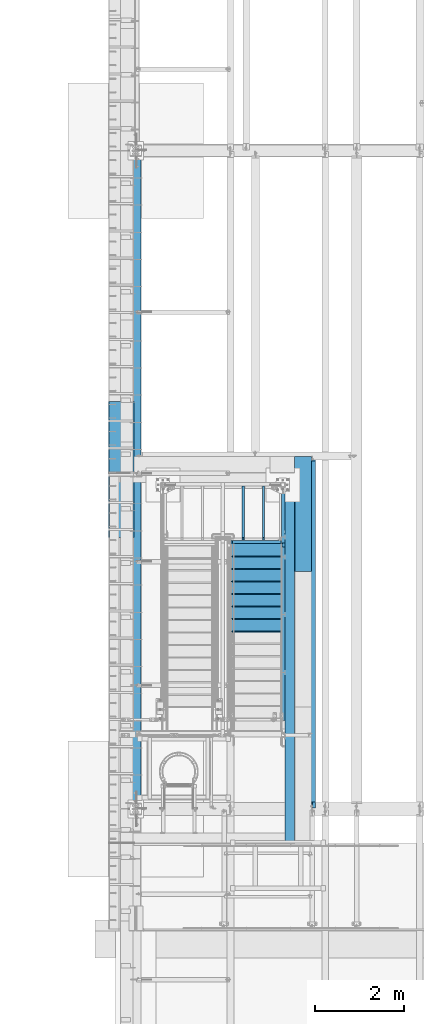
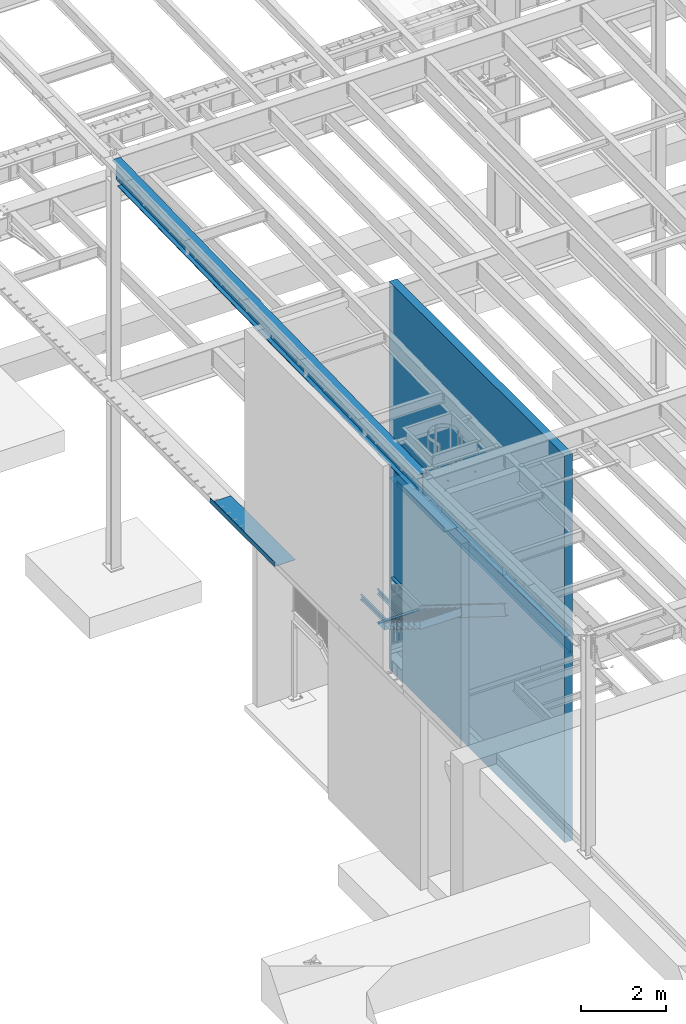
# One storey, part 1094 of 1763: 16 beams, 1 member, 6 elements without a shape of their own.
"""IFC2X3 building model written with IfcOpenShell, lengths in millimetres."""

from ifc_helpers import new_model, si_unit, frame, origin_with_axes, place, context, subcontext, project, spatial, faceted_brep, material, type_object, element, aggregate, save


model = new_model("IFC2X3")

# Units and contexts
model_context = context("Model", 3, precision=1e-05, world=origin_with_axes())
body_context = subcontext(model_context, "Body", "Model", "MODEL_VIEW")
ifc_project = project(units=[si_unit("LENGTHUNIT", "METRE", prefix="MILLI"), si_unit("AREAUNIT", "SQUARE_METRE"), si_unit("VOLUMEUNIT", "CUBIC_METRE"), si_unit("MASSUNIT", "GRAM", prefix="KILO"), si_unit("TIMEUNIT", "SECOND"), si_unit("PLANEANGLEUNIT", "RADIAN"), si_unit("SOLIDANGLEUNIT", "STERADIAN"), si_unit("THERMODYNAMICTEMPERATUREUNIT", "DEGREE_CELSIUS"), si_unit("LUMINOUSINTENSITYUNIT", "LUMEN")], contexts=[model_context])

# Site, building, storey
site_placement = place(None, origin_with_axes())
site = spatial("IfcSite", under=ifc_project, at=site_placement, CompositionType="ELEMENT")
building_placement = place(site_placement, origin_with_axes())
building = spatial("IfcBuilding", under=site, at=building_placement, Name="Undefined", CompositionType="ELEMENT")
storey_placement = place(building_placement, origin_with_axes())
storey = spatial("IfcBuildingStorey", under=building, at=storey_placement, Name="Undefined", CompositionType="ELEMENT", Elevation=0.0)

# Assembly, beam
assembly_1_placement = place(storey_placement, origin_with_axes())
assembly_1 = element("IfcElementAssembly", 1, at=assembly_1_placement, inside=storey, Name="STRINGER", AssemblyPlace="NOTDEFINED", PredefinedType="RIGID_FRAME")
ifc_material_1 = material(Name="STEEL/A36")
beam_type_1 = type_object("IfcBeamType", Name="C12X20.7", PredefinedType="NOTDEFINED")
beam_1_placement = place(assembly_1_placement, frame((-84060.6721013138, 35993.5867660648, 2630.48750000862), z_axis=(0.0, 0.0, 1.0), x_axis=(0.0, 1.0, 0.0)))
beam_1 = element("IfcBeam", 2, at=beam_1_placement, type_object=beam_type_1, material=ifc_material_1, Name="STRINGER", ObjectType="C12X20.7", context=body_context, shape_type="Brep", body=[
    faceted_brep([(-86.9205864272517, 38.1000000000058, -152.4), (0.0, 38.1000000000004, 152.4), (1357.1132351927, 38.1000000000058, 152.4), (1357.1132351927, 38.1000000000058, -152.4), (0.0, -38.1000000000004, 152.4), (1357.1132351927, -38.1000000000058, 152.4), (-1.81156772031682, -38.1000000000058, 146.04746), (1357.1132351927, -38.1000000000058, 146.04746), (-5.05470164173312, 30.1625000000058, 134.6749275), (1357.1132351927, 30.1625000000058, 134.6749275), (-81.8658825708844, 30.1625000000058, -134.6749275), (1357.1132351927, 30.1625000000058, -134.6749275), (-85.109016492308, -38.1000000000058, -146.04746), (1357.1132351927, -38.1000000000058, -146.04746), (-86.9205864272517, -38.1000000000058, -152.4), (1357.1132351927, -38.1000000000058, -152.4)], [[[0, 1, 2, 3]], [[1, 4, 5, 2]], [[4, 6, 7, 5]], [[6, 8, 9, 7]], [[8, 10, 11, 9]], [[10, 12, 13, 11]], [[12, 14, 15, 13]], [[14, 0, 3, 15]], [[5, 7, 9, 11, 13, 15, 3, 2]], [[14, 12, 10, 8, 6, 4, 1, 0]]]),
])

# Assembly, beams
assembly_2_placement = place(storey_placement, origin_with_axes())
assembly_2 = element("IfcElementAssembly", 3, at=assembly_2_placement, inside=storey, Name="STRINGER", AssemblyPlace="NOTDEFINED", PredefinedType="RIGID_FRAME")
beam_type_2 = type_object("IfcBeamType", Name="C6X8.2", PredefinedType="NOTDEFINED")
beam_2_placement = place(assembly_2_placement, frame((-84962.5034200538, 36061.6500002742, 2579.68749999999), z_axis=(0.0, 0.0, -1.0), x_axis=(0.0, 1.0, 0.0)))
beam_2 = element("IfcBeam", 4, at=beam_2_placement, type_object=beam_type_2, material=ifc_material_1, Name="BEAM", ObjectType="C6X8.2", context=body_context, shape_type="Brep", body=[
    faceted_brep([(57.1500002860994, -23.8125, -76.2000000013695), (53.1796626072537, -23.8125, -72.2296624999999), (50.800000858304, -9.52881209726911, -69.8500000954054), (50.800000858304, 23.8125, -69.8500000954054), (57.1500002860994, 23.8125, -76.1999999999998), (0.0, -23.8125, 72.2296624999999), (0.0, 19.0500000000029, 65.0887699999998), (1212.84999972743, 19.0500000000029, 65.0887699999998), (1212.84999972743, -23.8125, 72.2296624999999), (0.0, -23.8125, 76.1999999999998), (1212.84999972743, -23.8125, 76.1999999999998), (0.0, 23.8125, 76.1999999999998), (1212.84999972743, 23.8125, 76.1999999999998), (0.0, 23.8125, -50.8000003814695), (0.0, 19.0500000000029, -50.8000003814695), (38.1000010490388, 23.8125, -50.8000003814695), (38.1000010490388, 19.0500000000029, -50.8000003814695), (42.9600805670852, 23.8125, -51.7667303040575), (42.9600805670852, 19.0500000000029, -51.7667303040575), (47.0802570352389, 23.8125, -54.5197442045355), (47.0802570352389, 19.0500000000029, -54.5197442045355), (49.8332709357128, 23.8125, -58.6399206726892), (49.8332709357128, 19.0500000000029, -58.6399206726892), (50.800000858304, 23.8125, -63.5000001907347), (50.800000858304, 19.0500000000029, -63.5000001907347), (1212.84999972743, 19.0500000000029, -65.0887699999998), (50.800000858304, 19.0500000000029, -65.0887699999998), (1212.84999972743, -23.8125, -72.2296624999999), (1212.84999972743, -23.8125, -76.1999999999998), (1212.84999972743, 23.8125, -76.1999999999998)], [[[0, 1, 2, 3, 4]], [[5, 6, 7, 8]], [[9, 5, 8, 10]], [[11, 9, 10, 12]], [[6, 5, 9, 11, 13, 14]], [[14, 13, 15, 16]], [[16, 15, 17, 18]], [[18, 17, 19, 20]], [[20, 19, 21, 22]], [[22, 21, 23, 24]], [[25, 7, 6, 14, 16, 18, 20, 22, 24, 26]], [[10, 8, 7, 25, 27, 28, 29, 12]], [[29, 28, 0, 4]], [[23, 21, 19, 17, 15, 13, 11, 12, 29, 4, 3]], [[26, 24, 23, 3, 2]], [[27, 25, 26, 2, 1]], [[28, 27, 1, 0]]]),
])
beam_3_placement = place(assembly_2_placement, frame((-84505.1711283956, 36061.6500002742, 2579.68749999999), z_axis=(0.0, 0.0, -1.0), x_axis=(0.0, 1.0, 0.0)))
beam_3 = element("IfcBeam", 5, at=beam_3_placement, type_object=beam_type_2, material=ifc_material_1, Name="BEAM", ObjectType="C6X8.2", context=body_context, shape_type="Brep", body=[
    faceted_brep([(57.1500002860994, -23.8125, -76.2000000013695), (53.1796626072537, -23.8125, -72.2296624999999), (50.800000858304, -9.52881209726911, -69.8500000954054), (50.800000858304, 23.8125, -69.8500000954054), (57.1500002860994, 23.8125, -76.1999999999998), (0.0, -23.8125, 72.2296624999999), (0.0, 19.0500000000029, 65.0887699999998), (1212.84999972743, 19.0500000000029, 65.0887699999998), (1212.84999972743, -23.8125, 72.2296624999999), (0.0, -23.8125, 76.1999999999998), (1212.84999972743, -23.8125, 76.1999999999998), (0.0, 23.8125, 76.1999999999998), (1212.84999972743, 23.8125, 76.1999999999998), (0.0, 23.8125, -50.8000003814695), (0.0, 19.0500000000029, -50.8000003814695), (38.1000010490388, 23.8125, -50.8000003814695), (38.1000010490388, 19.0500000000029, -50.8000003814695), (42.9600805670852, 23.8125, -51.7667303040575), (42.9600805670852, 19.0500000000029, -51.7667303040575), (47.0802570352389, 23.8125, -54.5197442045355), (47.0802570352389, 19.0500000000029, -54.5197442045355), (49.8332709357128, 23.8125, -58.6399206726892), (49.8332709357128, 19.0500000000029, -58.6399206726892), (50.800000858304, 23.8125, -63.5000001907347), (50.800000858304, 19.0500000000029, -63.5000001907347), (1212.84999972743, 19.0500000000029, -65.0887699999998), (50.800000858304, 19.0500000000029, -65.0887699999998), (1212.84999972743, -23.8125, -72.2296624999999), (1212.84999972743, -23.8125, -76.1999999999998), (1212.84999972743, 23.8125, -76.1999999999998)], [[[0, 1, 2, 3, 4]], [[5, 6, 7, 8]], [[9, 5, 8, 10]], [[11, 9, 10, 12]], [[6, 5, 9, 11, 13, 14]], [[14, 13, 15, 16]], [[16, 15, 17, 18]], [[18, 17, 19, 20]], [[20, 19, 21, 22]], [[22, 21, 23, 24]], [[25, 7, 6, 14, 16, 18, 20, 22, 24, 26]], [[10, 8, 7, 25, 27, 28, 29, 12]], [[29, 28, 0, 4]], [[23, 21, 19, 17, 15, 13, 11, 12, 29, 4, 3]], [[26, 24, 23, 3, 2]], [[27, 25, 26, 2, 1]], [[28, 27, 1, 0]]]),
])
beam_type_3 = type_object("IfcBeamType", Name="L3X3X1/4", PredefinedType="NOTDEFINED")
beam_4_placement = place(assembly_2_placement, frame((-84111.5372737356, 36017.2000003691, 2640.01249999956), z_axis=(0.0, 0.0, -1.0), x_axis=(-1.0, 0.0, 0.0)))
beam_4 = element("IfcBeam", 6, at=beam_4_placement, type_object=beam_type_3, material=ifc_material_1, Name="ANGLE", ObjectType="L3X3X1/4", context=body_context, shape_type="Brep", body=[
    faceted_brep([(12.7000009168405, 31.75, 38.0999999999999), (12.7000009168405, 31.75, -3.17500000044265), (12.7000009168405, 38.0999999999985, -3.17500000044265), (12.7000009168405, 38.0999999999985, 38.0999999999999), (88.8348275769968, 31.75, -3.17500000044356), (88.8348275769968, 38.0999999999985, -3.17500000044356), (88.8348275769968, 31.75, 38.1000015254353), (88.8348275769968, 38.0999999999985, 38.0999999999999), (0.0, -38.1000000000004, -31.75), (0.0, -38.0999999999985, -38.1000000000004), (1092.13482757374, -38.0999999999985, -38.0999999999999), (1092.13482757374, -38.0999999999985, -31.75), (0.0, 31.75, -31.75), (1092.13482757374, 31.75, -31.75), (0.0, 31.75, 38.1000000000058), (0.0, 38.0999999999985, 38.1000000000004), (0.0, 38.0999999999985, -38.1000000000004), (1092.13482757374, 38.0999999999985, -38.0999999999999), (1092.13482757374, 31.75, 38.0999999999999), (1092.13482757374, 38.0999999999985, 38.0999999999999)], [[[0, 1, 2, 3]], [[4, 5, 2, 1]], [[6, 7, 5, 4]], [[8, 9, 10, 11]], [[12, 8, 11, 13]], [[9, 8, 12, 14, 15, 16]], [[9, 16, 17, 10]], [[18, 13, 11, 10, 17, 19]], [[1, 0, 14, 12, 13, 18, 6, 4]], [[15, 14, 0, 3]], [[19, 17, 16, 15, 3, 2, 5, 7]], [[18, 19, 7, 6]]]),
])
aggregate(assembly_2, [beam_2, beam_3, beam_4])

# Member
member_type = type_object("IfcMemberType", Name="C12X20.7", PredefinedType="NOTDEFINED")
member_placement = place(assembly_1_placement, frame((-84060.6721012877, 31722.2032358378, 5255.32317481212), z_axis=(0.0, 0.527450977296466, 0.849585467477524), x_axis=(0.0, 0.849585467029409, -0.527450978018262)))
member = element("IfcMember", 7, at=member_placement, type_object=member_type, material=ifc_material_1, Name="STRINGER", ObjectType="C12X20.7", context=body_context, shape_type="Brep", body=[
    faceted_brep([(327.701259389734, 38.1000000000058, -152.400000000143), (240.780670510492, 38.1000000000058, 152.39999999998), (4932.99398815697, 38.1000000000058, 152.399999998623), (5019.9145771266, 38.1000000000058, -152.4000000015), (240.780670510492, -38.1000000000058, 152.39999999998), (4932.99398815697, -38.1000000000058, 152.399999998623), (242.592240450376, -38.1000000000058, 146.047459999972), (4934.80555809874, -38.1000000000058, 146.047459998619), (245.835374380655, 30.1625000000058, 134.674927499971), (4938.0486920324, 30.1625000000058, 134.674927498618), (322.646555519568, 30.1625000000058, -134.674927500131), (5014.85987325117, 30.1625000000058, -134.674927501492), (325.889689449843, -38.1000000000058, -146.04746000014), (5018.10300718483, -38.1000000000058, -146.047460001493), (327.701259389734, -38.1000000000058, -152.400000000143), (5019.9145771266, -38.1000000000058, -152.4000000015)], [[[0, 1, 2, 3]], [[1, 4, 5, 2]], [[4, 6, 7, 5]], [[6, 8, 9, 7]], [[8, 10, 11, 9]], [[10, 12, 13, 11]], [[12, 14, 15, 13]], [[14, 0, 3, 15]], [[5, 7, 9, 11, 13, 15, 3, 2]], [[14, 12, 10, 8, 6, 4, 1, 0]]]),
])

# Assembly, beams
assembly_3_placement = place(storey_placement, origin_with_axes())
assembly_3 = element("IfcElementAssembly", 8, at=assembly_3_placement, inside=storey, Name="BEAM", AssemblyPlace="NOTDEFINED", PredefinedType="RIGID_FRAME")
ifc_material_2 = material(Name="STEEL/A992")
beam_type_4 = type_object("IfcBeamType", Name="W16X26", PredefinedType="NOTDEFINED")
beam_5_placement = place(assembly_3_placement, frame((-83413.0372736983, 30022.8, 4994.275), z_axis=(0.0, 0.0, 1.0), x_axis=(0.0, 1.0, 0.0)))
beam_5 = element("IfcBeam", 9, at=beam_5_placement, type_object=beam_type_4, material=ifc_material_2, Name="BEAM", ObjectType="W16X26", context=body_context, shape_type="Brep", body=[
    faceted_brep([(7818.437500757, -69.8500000000058, 200.025), (7818.437500757, -69.8500000000058, 190.5), (7818.437500757, -3.17500000000291, 190.5), (7818.437500757, -3.17500000000291, 187.065001487732), (7818.437500757, 3.17500000000291, 187.065001487732), (7818.437500757, 3.17500000000291, 190.5), (7818.437500757, 69.8500000000058, 190.5), (7818.437500757, 69.8500000000058, 200.025), (7819.40423067959, -3.17500000000291, 182.204921969686), (7819.40423067959, 3.17500000000291, 182.204921969686), (7822.15724458006, -3.17500000000291, 178.084745501533), (7822.15724458006, 3.17500000000291, 178.084745501533), (7826.27742104822, -3.17500000000291, 175.331731601054), (7826.27742104822, 3.17500000000291, 175.331731601054), (7831.13750056626, -3.17500000000291, 174.365001678467), (7831.13750056626, 3.17500000000291, 174.365001678467), (7907.33750000002, -3.17500000000291, 174.365001678467), (7907.33750000002, 3.17500000000291, 174.365001678467), (159.543749432261, -69.8499999999985, 200.025), (159.543749432261, 69.8499999999985, 200.025), (159.543749432261, 69.8499999999985, 190.5), (159.543749432261, 3.17500000000291, 190.5), (159.543749432261, 3.17500000000291, 180.715001487732), (159.543749432261, -3.17500000000291, 180.715001487732), (159.543749432261, -3.17500000000291, 190.5), (159.543749432261, -69.8499999999985, 190.5), (158.57701950967, 3.17500000000291, 175.854921969686), (158.57701950967, -3.17500000000291, 175.854921969686), (155.824005609196, 3.17500000000291, 171.734745501532), (155.824005609196, -3.17500000000291, 171.734745501532), (151.703829141043, 3.17500000000291, 168.981731601054), (151.703829141043, -3.17500000000291, 168.981731601054), (146.843749622996, 3.17500000000291, 168.015001678466), (146.843749622996, -3.17500000000291, 168.015001678466), (19.84375, 3.17500000000291, 168.015001678466), (19.84375, -3.17500000000291, 168.015001678466), (19.84375, 3.17500000000291, -190.5), (19.84375, 69.8499999999985, -190.5), (19.84375, 69.8499999999985, -200.025), (19.84375, -69.8499999999985, -200.025), (19.84375, -69.8499999999985, -190.5), (19.84375, -3.17500000000291, -190.5), (7907.33750000002, 3.17500000000291, -190.5), (7907.33750000002, 69.8500000000058, -190.5), (7907.33750000002, 69.8500000000058, -200.025), (7907.33750000002, -69.8500000000058, -200.025), (7907.33750000002, -69.8500000000058, -190.5), (7907.33750000002, -3.17500000000291, -190.5)], [[[0, 1, 2, 3, 4, 5, 6, 7]], [[8, 9, 4, 3]], [[10, 11, 9, 8]], [[12, 13, 11, 10]], [[14, 15, 13, 12]], [[16, 17, 15, 14]], [[18, 19, 20, 21, 22, 23, 24, 25]], [[23, 22, 26, 27]], [[27, 26, 28, 29]], [[29, 28, 30, 31]], [[31, 30, 32, 33]], [[33, 32, 34, 35]], [[36, 37, 38, 39, 40, 41, 35, 34]], [[37, 36, 42, 43]], [[38, 37, 43, 44]], [[39, 38, 44, 45]], [[40, 39, 45, 46]], [[41, 40, 46, 47]], [[12, 10, 8, 3, 2, 24, 23, 27, 29, 31, 33, 35, 41, 47, 16, 14]], [[25, 24, 2, 1]], [[18, 25, 1, 0]], [[19, 18, 0, 7]], [[20, 19, 7, 6]], [[21, 20, 6, 5]], [[42, 36, 34, 32, 30, 28, 26, 22, 21, 5, 4, 9, 11, 13, 15, 17]], [[47, 46, 45, 44, 43, 42, 17, 16]]]),
])
beam_type_5 = type_object("IfcBeamType", PredefinedType="NOTDEFINED")
beam_6_placement = place(assembly_3_placement, frame((-83425.7372736983, 36645.45325, 5199.0625), z_axis=(0.0, -1.0, 0.0), x_axis=(-1.0, 0.0, 0.0)))
beam_6 = element("IfcBeam", 10, at=beam_6_placement, type_object=beam_type_5, material=ifc_material_1, Name="BENT_PLATE", context=body_context, shape_type="Brep", body=[
    faceted_brep([(381.0, -4.76250351519593, -930.671773681643), (371.475000000006, -4.76249999999982, -930.671773681643), (371.475000000006, -4.76249999999982, -1289.4475), (381.0, -4.76035200819024, -1289.4475), (381.000000000335, -134.937497028337, -930.671773681643), (371.475000000006, -134.937496948242, -930.671773681643), (0.0, 4.76249999999982, -1289.4475), (0.0, 4.76249999999982, 1289.4475), (381.0, 4.76249999999982, 1289.4475), (381.0, 4.76249999999982, -1289.4475), (0.0, -4.76249999999982, -1289.4475), (0.0, -4.76249999999982, 1289.4475), (371.475000000006, -4.76249999999982, 1289.4475), (371.475000000006, -134.937496948242, 1289.4475), (381.0, -134.937496948242, 1289.4475)], [[[0, 1, 2, 3]], [[4, 5, 1, 0]], [[6, 7, 8, 9]], [[10, 11, 7, 6]], [[8, 7, 11, 12, 13, 14]], [[3, 9, 8, 14, 4, 0]], [[10, 6, 9, 3, 2]], [[12, 11, 10, 2, 1]], [[13, 12, 1, 5]], [[14, 13, 5, 4]]]),
])
aggregate(assembly_3, [beam_6, beam_5])

# Beam
beam_type_6 = type_object("IfcBeamType", PredefinedType="NOTDEFINED")
beam_7_placement = place(assembly_1_placement, frame((-84670.2721013125, 35674.3000011564, 2903.96083334418), z_axis=(-1.0, 0.0, 0.0), x_axis=(0.0, 1.0, 0.0)))
beam_7 = element("IfcBeam", 11, at=beam_7_placement, type_object=beam_type_6, material=ifc_material_1, Name="TREAD", context=body_context, shape_type="Brep", body=[
    faceted_brep([(0.0, -1.58749999999964, -571.5), (0.0, -1.58749999999964, 571.5), (0.0, 1.58749999999964, 571.5), (0.0, 1.58749999999964, -571.5), (21.7262234107766, 1.58750000001965, 571.5), (21.7262234107766, 1.58750000001965, -571.5), (25.3999996185303, -1.58749999999998, -571.5), (25.3999996185303, -1.58749999999998, 571.5), (-11.1124582870689, 225.848333740234, 571.5), (-11.1124582870689, 225.848333740234, -571.5), (-7.43868207930791, 222.673333740234, -571.5), (-7.43868207930791, 222.673333740234, 571.5), (381.0, 225.848333740234, 571.5), (381.0, 225.848333740234, -571.5), (381.0, 222.673333740234, 571.5), (381.0, 222.673333740234, -571.5)], [[[0, 1, 2, 3]], [[3, 2, 4, 5]], [[1, 0, 6, 7]], [[5, 4, 8, 9]], [[7, 6, 10, 11]], [[9, 8, 12, 13]], [[8, 4, 2, 1, 7, 11, 14, 12]], [[11, 10, 15, 14]], [[10, 6, 0, 3, 5, 9, 13, 15]], [[14, 15, 13, 12]]]),
])

beam_type_7 = type_object("IfcBeamType", PredefinedType="NOTDEFINED")
beam_8_placement = place(assembly_1_placement, frame((-84670.2721013125, 35394.9000010727, 3077.42166667774), z_axis=(-1.0, 0.0, 0.0), x_axis=(0.0, 1.0, 0.0)))
beam_8 = element("IfcBeam", 12, at=beam_8_placement, type_object=beam_type_7, material=ifc_material_1, Name="TREAD", context=body_context, shape_type="Brep", body=[
    faceted_brep([(0.0, -1.58749999999964, -571.5), (0.0, -1.58749999999964, 571.5), (0.0, 1.58749999999964, 571.5), (0.0, 1.58749999999964, -571.5), (21.7262234107766, 1.58750000001965, 571.5), (21.7262234107766, 1.58750000001965, -571.5), (25.3999996185303, -1.58749999999998, -571.5), (25.3999996185303, -1.58749999999998, 571.5), (-11.1124582870689, 225.848333740234, 571.5), (-11.1124582870689, 225.848333740234, -571.5), (-7.43868207930791, 222.673333740234, -571.5), (-7.43868207930791, 222.673333740234, 571.5), (293.687544632128, 225.848333740234, 571.5), (293.687544632128, 225.848333740234, -571.5), (290.943603515625, 222.673333740234, -571.5), (290.943603515625, 222.673333740234, 571.5), (299.605243823971, 185.435362772942, 571.5), (299.605243823971, 185.435362772942, -571.5), (296.463745117188, 184.975350952148, 571.5), (296.463745117188, 184.975350952148, -571.5)], [[[0, 1, 2, 3]], [[3, 2, 4, 5]], [[1, 0, 6, 7]], [[5, 4, 8, 9]], [[7, 6, 10, 11]], [[9, 8, 12, 13]], [[11, 10, 14, 15]], [[13, 12, 16, 17]], [[12, 8, 4, 2, 1, 7, 11, 15, 18, 16]], [[15, 14, 19, 18]], [[14, 10, 6, 0, 3, 5, 9, 13, 17, 19]], [[18, 19, 17, 16]]]),
])

beam_9_placement = place(assembly_1_placement, frame((-84670.272101313, 33997.900000668, 3944.72583334658), z_axis=(-1.0, 0.0, 0.0), x_axis=(0.0, 1.0, 0.0)))
beam_9 = element("IfcBeam", 13, at=beam_9_placement, type_object=beam_type_7, material=ifc_material_1, Name="TREAD", context=body_context, shape_type="Brep", body=[
    faceted_brep([(0.0, -1.58749999999964, -571.5), (0.0, -1.58749999999964, 571.5), (0.0, 1.58749999999964, 571.5), (0.0, 1.58749999999964, -571.5), (21.7262234107766, 1.58750000001965, 571.5), (21.7262234107766, 1.58750000001965, -571.5), (25.3999996185303, -1.58749999999998, -571.5), (25.3999996185303, -1.58749999999998, 571.5), (-11.1124582870689, 225.848333740234, 571.5), (-11.1124582870689, 225.848333740234, -571.5), (-7.43868207930791, 222.673333740234, -571.5), (-7.43868207930791, 222.673333740234, 571.5), (293.687544632128, 225.848333740234, 571.5), (293.687544632128, 225.848333740234, -571.5), (290.943603515625, 222.673333740234, -571.5), (290.943603515625, 222.673333740234, 571.5), (299.605243823971, 185.435362772942, 571.5), (299.605243823971, 185.435362772942, -571.5), (296.463745117188, 184.975350952148, 571.5), (296.463745117188, 184.975350952148, -571.5)], [[[0, 1, 2, 3]], [[3, 2, 4, 5]], [[1, 0, 6, 7]], [[5, 4, 8, 9]], [[7, 6, 10, 11]], [[9, 8, 12, 13]], [[11, 10, 14, 15]], [[13, 12, 16, 17]], [[12, 8, 4, 2, 1, 7, 11, 15, 18, 16]], [[15, 14, 19, 18]], [[14, 10, 6, 0, 3, 5, 9, 13, 17, 19]], [[18, 19, 17, 16]]]),
])

beam_10_placement = place(assembly_1_placement, frame((-84670.272101313, 34277.3000007519, 3771.26500001324), z_axis=(-1.0, 0.0, 0.0), x_axis=(0.0, 1.0, 0.0)))
beam_10 = element("IfcBeam", 14, at=beam_10_placement, type_object=beam_type_7, material=ifc_material_1, Name="TREAD", context=body_context, shape_type="Brep", body=[
    faceted_brep([(0.0, -1.58749999999964, -571.5), (0.0, -1.58749999999964, 571.5), (0.0, 1.58749999999964, 571.5), (0.0, 1.58749999999964, -571.5), (21.7262234107766, 1.58750000001965, 571.5), (21.7262234107766, 1.58750000001965, -571.5), (25.3999996185303, -1.58749999999998, -571.5), (25.3999996185303, -1.58749999999998, 571.5), (-11.1124582870689, 225.848333740234, 571.5), (-11.1124582870689, 225.848333740234, -571.5), (-7.43868207930791, 222.673333740234, -571.5), (-7.43868207930791, 222.673333740234, 571.5), (293.687544632128, 225.848333740234, 571.5), (293.687544632128, 225.848333740234, -571.5), (290.943603515625, 222.673333740234, -571.5), (290.943603515625, 222.673333740234, 571.5), (299.605243823971, 185.435362772942, 571.5), (299.605243823971, 185.435362772942, -571.5), (296.463745117188, 184.975350952148, 571.5), (296.463745117188, 184.975350952148, -571.5)], [[[0, 1, 2, 3]], [[3, 2, 4, 5]], [[1, 0, 6, 7]], [[5, 4, 8, 9]], [[7, 6, 10, 11]], [[9, 8, 12, 13]], [[11, 10, 14, 15]], [[13, 12, 16, 17]], [[12, 8, 4, 2, 1, 7, 11, 15, 18, 16]], [[15, 14, 19, 18]], [[14, 10, 6, 0, 3, 5, 9, 13, 17, 19]], [[18, 19, 17, 16]]]),
])

beam_11_placement = place(assembly_1_placement, frame((-84670.272101313, 34556.7000008358, 3597.80416667991), z_axis=(-1.0, 0.0, 0.0), x_axis=(0.0, 1.0, 0.0)))
beam_11 = element("IfcBeam", 15, at=beam_11_placement, type_object=beam_type_7, material=ifc_material_1, Name="TREAD", context=body_context, shape_type="Brep", body=[
    faceted_brep([(0.0, -1.58749999999964, -571.5), (0.0, -1.58749999999964, 571.5), (0.0, 1.58749999999964, 571.5), (0.0, 1.58749999999964, -571.5), (21.7262234107766, 1.58750000001965, 571.5), (21.7262234107766, 1.58750000001965, -571.5), (25.3999996185303, -1.58749999999998, -571.5), (25.3999996185303, -1.58749999999998, 571.5), (-11.1124582870689, 225.848333740234, 571.5), (-11.1124582870689, 225.848333740234, -571.5), (-7.43868207930791, 222.673333740234, -571.5), (-7.43868207930791, 222.673333740234, 571.5), (293.687544632128, 225.848333740234, 571.5), (293.687544632128, 225.848333740234, -571.5), (290.943603515625, 222.673333740234, -571.5), (290.943603515625, 222.673333740234, 571.5), (299.605243823971, 185.435362772942, 571.5), (299.605243823971, 185.435362772942, -571.5), (296.463745117188, 184.975350952148, 571.5), (296.463745117188, 184.975350952148, -571.5)], [[[0, 1, 2, 3]], [[3, 2, 4, 5]], [[1, 0, 6, 7]], [[5, 4, 8, 9]], [[7, 6, 10, 11]], [[9, 8, 12, 13]], [[11, 10, 14, 15]], [[13, 12, 16, 17]], [[12, 8, 4, 2, 1, 7, 11, 15, 18, 16]], [[15, 14, 19, 18]], [[14, 10, 6, 0, 3, 5, 9, 13, 17, 19]], [[18, 19, 17, 16]]]),
])

beam_12_placement = place(assembly_1_placement, frame((-84670.272101313, 34836.1000009197, 3424.34333334658), z_axis=(-1.0, 0.0, 0.0), x_axis=(0.0, 1.0, 0.0)))
beam_12 = element("IfcBeam", 16, at=beam_12_placement, type_object=beam_type_7, material=ifc_material_1, Name="TREAD", context=body_context, shape_type="Brep", body=[
    faceted_brep([(0.0, -1.58749999999964, -571.5), (0.0, -1.58749999999964, 571.5), (0.0, 1.58749999999964, 571.5), (0.0, 1.58749999999964, -571.5), (21.7262234107766, 1.58750000001965, 571.5), (21.7262234107766, 1.58750000001965, -571.5), (25.3999996185303, -1.58749999999998, -571.5), (25.3999996185303, -1.58749999999998, 571.5), (-11.1124582870689, 225.848333740234, 571.5), (-11.1124582870689, 225.848333740234, -571.5), (-7.43868207930791, 222.673333740234, -571.5), (-7.43868207930791, 222.673333740234, 571.5), (293.687544632128, 225.848333740234, 571.5), (293.687544632128, 225.848333740234, -571.5), (290.943603515625, 222.673333740234, -571.5), (290.943603515625, 222.673333740234, 571.5), (299.605243823971, 185.435362772942, 571.5), (299.605243823971, 185.435362772942, -571.5), (296.463745117188, 184.975350952148, 571.5), (296.463745117188, 184.975350952148, -571.5)], [[[0, 1, 2, 3]], [[3, 2, 4, 5]], [[1, 0, 6, 7]], [[5, 4, 8, 9]], [[7, 6, 10, 11]], [[9, 8, 12, 13]], [[11, 10, 14, 15]], [[13, 12, 16, 17]], [[12, 8, 4, 2, 1, 7, 11, 15, 18, 16]], [[15, 14, 19, 18]], [[14, 10, 6, 0, 3, 5, 9, 13, 17, 19]], [[18, 19, 17, 16]]]),
])

beam_13_placement = place(assembly_1_placement, frame((-84670.272101313, 35115.5000010036, 3250.88250001334), z_axis=(-1.0, 0.0, 0.0), x_axis=(0.0, 1.0, 0.0)))
beam_13 = element("IfcBeam", 17, at=beam_13_placement, type_object=beam_type_7, material=ifc_material_1, Name="TREAD", context=body_context, shape_type="Brep", body=[
    faceted_brep([(0.0, -1.58749999999964, -571.5), (0.0, -1.58749999999964, 571.5), (0.0, 1.58749999999964, 571.5), (0.0, 1.58749999999964, -571.5), (21.7262234107766, 1.58750000001965, 571.5), (21.7262234107766, 1.58750000001965, -571.5), (25.3999996185303, -1.58749999999998, -571.5), (25.3999996185303, -1.58749999999998, 571.5), (-11.1124582870689, 225.848333740234, 571.5), (-11.1124582870689, 225.848333740234, -571.5), (-7.43868207930791, 222.673333740234, -571.5), (-7.43868207930791, 222.673333740234, 571.5), (293.687544632128, 225.848333740234, 571.5), (293.687544632128, 225.848333740234, -571.5), (290.943603515625, 222.673333740234, -571.5), (290.943603515625, 222.673333740234, 571.5), (299.605243823971, 185.435362772942, 571.5), (299.605243823971, 185.435362772942, -571.5), (296.463745117188, 184.975350952148, 571.5), (296.463745117188, 184.975350952148, -571.5)], [[[0, 1, 2, 3]], [[3, 2, 4, 5]], [[1, 0, 6, 7]], [[5, 4, 8, 9]], [[7, 6, 10, 11]], [[9, 8, 12, 13]], [[11, 10, 14, 15]], [[13, 12, 16, 17]], [[12, 8, 4, 2, 1, 7, 11, 15, 18, 16]], [[15, 14, 19, 18]], [[14, 10, 6, 0, 3, 5, 9, 13, 17, 19]], [[18, 19, 17, 16]]]),
])

aggregate(assembly_1, [beam_7, beam_8, beam_9, beam_10, beam_11, beam_12, beam_13, beam_1, member])

# Assembly, beam
assembly_4_placement = place(storey_placement, origin_with_axes())
assembly_4 = element("IfcElementAssembly", 18, at=assembly_4_placement, inside=storey, Name="BEAM", AssemblyPlace="NOTDEFINED", PredefinedType="RIGID_FRAME")
beam_type_8 = type_object("IfcBeamType", PredefinedType="NOTDEFINED")
beam_14_placement = place(assembly_4_placement, frame((-87413.5372736984, 37645.9755, 5199.0625), z_axis=(0.0, -1.0, 0.0), x_axis=(-1.0, 0.0, 0.0)))
beam_14 = element("IfcBeam", 19, at=beam_14_placement, type_object=beam_type_8, material=ifc_material_1, Name="BENT_PLATE", context=body_context, shape_type="Brep", body=[
    faceted_brep([(0.0, -4.76249999999982, -1524.0), (0.0, -4.76249999999982, 1524.0), (0.0, 4.76249999999982, 1524.0), (0.0, 4.76249999999982, -1524.0), (571.5, 4.76249999999982, 1524.0), (571.5, 4.76249999999982, -1524.0), (561.975000000006, -4.76249999999982, -1524.0), (561.975000000006, -4.76249999999982, 1524.0), (571.5, -134.937496948242, 1524.0), (571.5, -134.937496948242, -1524.0), (561.975000000006, -134.937496948242, 1524.0), (561.975000000006, -134.937496948242, -1524.0)], [[[0, 1, 2, 3]], [[3, 2, 4, 5]], [[1, 0, 6, 7]], [[5, 4, 8, 9]], [[4, 2, 1, 7, 10, 8]], [[7, 6, 11, 10]], [[6, 0, 3, 5, 9, 11]], [[10, 11, 9, 8]]]),
])
aggregate(assembly_4, [beam_14])

assembly_5_placement = place(storey_placement, origin_with_axes())
assembly_5 = element("IfcElementAssembly", 20, at=assembly_5_placement, inside=storey, Name="BEAM", AssemblyPlace="NOTDEFINED", PredefinedType="RIGID_FRAME")
beam_type_9 = type_object("IfcBeamType", Name="W24X76", PredefinedType="NOTDEFINED")
beam_15_placement = place(assembly_5_placement, frame((-87375.4372736983, 30029.0720198233, 10987.1523760151), z_axis=(0.0, -0.0206852279954837, 0.999786037781472), x_axis=(0.0, 0.999786037781472, 0.0206852279954825)))
beam_15 = element("IfcBeam", 21, at=beam_15_placement, type_object=beam_type_9, material=ifc_material_2, Name="BEAM", ObjectType="W24X76", context=body_context, shape_type="Brep", body=[
    faceted_brep([(14381.1968095528, 5.85641229666362, -285.750000002523), (14381.196809553, 5.85609071231738, -303.21250000251), (14381.1967663929, 114.300000000003, -303.21250000251), (14381.1967663929, 114.300000000003, -285.750000002523), (14629.2847904842, 5.85651103426062, -285.75000000257), (14628.9234973872, 5.85618930617056, -303.212500002557), (392.220055869548, 114.300000000003, -285.749999999858), (392.220055869548, 114.300000000003, -303.212499999845), (392.220095451798, 5.8564122995158, -303.212499999845), (392.220095451929, 5.85609071898216, -285.74999999986), (131.946692089903, 5.85631729957822, -303.212499999796), (132.307985186846, 5.85599585088494, -285.749999999809), (132.307985344094, -5.55625000000146, -285.749999999818), (144.132123062285, -5.55625000000146, 285.749999999749), (144.132123062285, -114.300000000003, 285.749999999749), (144.493416159225, -114.300000000003, 303.212499999736), (144.493416159225, 114.300000000003, 303.212499999736), (144.132123062285, 114.300000000003, 285.749999999749), (144.132123062285, 5.55625000000146, 285.749999999749), (132.307985344094, 5.55625000000146, -285.749999999818), (131.946692089903, -5.85618567850906, -303.212499999796), (132.307985186846, -5.85650712720235, -285.749999999809), (392.220099659167, -5.85609067720361, -303.212499999847), (392.220099659306, -5.85641225773725, -285.749999999858), (392.22013924181, -114.300000000003, -285.74999999986), (392.22013924181, -114.300000000003, -303.212499999845), (14381.1968573327, -114.300000000003, -303.21250000251), (14381.1968573327, -114.300000000003, -285.750000002523), (14381.1968141722, -5.85641229987959, -303.21250000251), (14381.196814172, -5.85609071553336, -285.750000002523), (14629.2847904842, -5.85599197649572, -285.75000000257), (14628.9234973872, -5.85631370458577, -303.212500002557), (14629.2847904842, -5.55624999999418, -285.75000000257), (14641.1089282023, -5.55624999999418, 285.749999996997), (14641.1089282023, -114.300000000003, 285.749999996997), (14641.4702212993, -114.300000000003, 303.212499996984), (14641.4702212993, 114.300000000003, 303.212499996984), (14641.1089282023, 114.300000000003, 285.749999996997), (14641.1089282023, 5.55624999999418, 285.749999996997), (14629.2847904842, 5.55624999999418, -285.75000000257)], [[[0, 1, 2, 3]], [[4, 5, 1, 0]], [[6, 7, 8, 9]], [[9, 8, 10, 11]], [[12, 13, 14, 15, 16, 17, 18, 19, 11, 10, 20, 21]], [[21, 20, 22, 23]], [[24, 23, 22, 25]], [[24, 25, 26, 27]], [[27, 26, 28, 29]], [[30, 29, 28, 31]], [[32, 12, 21, 23, 24, 27, 29, 30]], [[13, 12, 32, 33]], [[14, 13, 33, 34]], [[15, 14, 34, 35]], [[16, 15, 35, 36]], [[17, 16, 36, 37]], [[18, 17, 37, 38]], [[19, 18, 38, 39]], [[3, 6, 9, 11, 19, 39, 4, 0]], [[7, 6, 3, 2]], [[31, 28, 26, 25, 22, 20, 10, 8, 7, 2, 1, 5]], [[39, 38, 37, 36, 35, 34, 33, 32, 30, 31, 5, 4]]]),
])
aggregate(assembly_5, [beam_15])

assembly_6_placement = place(storey_placement, origin_with_axes())
assembly_6 = element("IfcElementAssembly", 22, at=assembly_6_placement, inside=storey, Name="WALL", AssemblyPlace="NOTDEFINED", PredefinedType="REINFORCEMENT_UNIT")
ifc_material_3 = material(Name="CONCRETE/5000")
beam_type_10 = type_object("IfcBeamType", PredefinedType="NOTDEFINED")
beam_16_placement = place(assembly_6_placement, frame((-83914.6872736983, 29260.7999999971, 5588.0), z_axis=(-1.0, 0.0, 0.0), x_axis=(0.0, 1.0, 0.0)))
beam_16 = element("IfcBeam", 23, at=beam_16_placement, type_object=beam_type_10, material=ifc_material_3, Name="WALL", context=body_context, shape_type="Brep", body=[
    faceted_brep([(0.0, 5588.0, -107.949999999997), (0.0, 5588.0, 107.949999999997), (8305.80000000296, 5588.0, 107.949999999997), (8305.80000000296, 5588.0, -107.949999999997), (0.0, -5588.0, 107.949999999997), (8305.80000000296, -5588.0, 107.949999999997), (0.0, -5588.0, -107.949999999997), (8305.80000000296, -5588.0, -107.949999999997)], [[[0, 1, 2, 3]], [[1, 4, 5, 2]], [[4, 6, 7, 5]], [[6, 0, 3, 7]], [[5, 7, 3, 2]], [[6, 4, 1, 0]]]),
])
aggregate(assembly_6, [beam_16])

save(model, "model.ifc")
